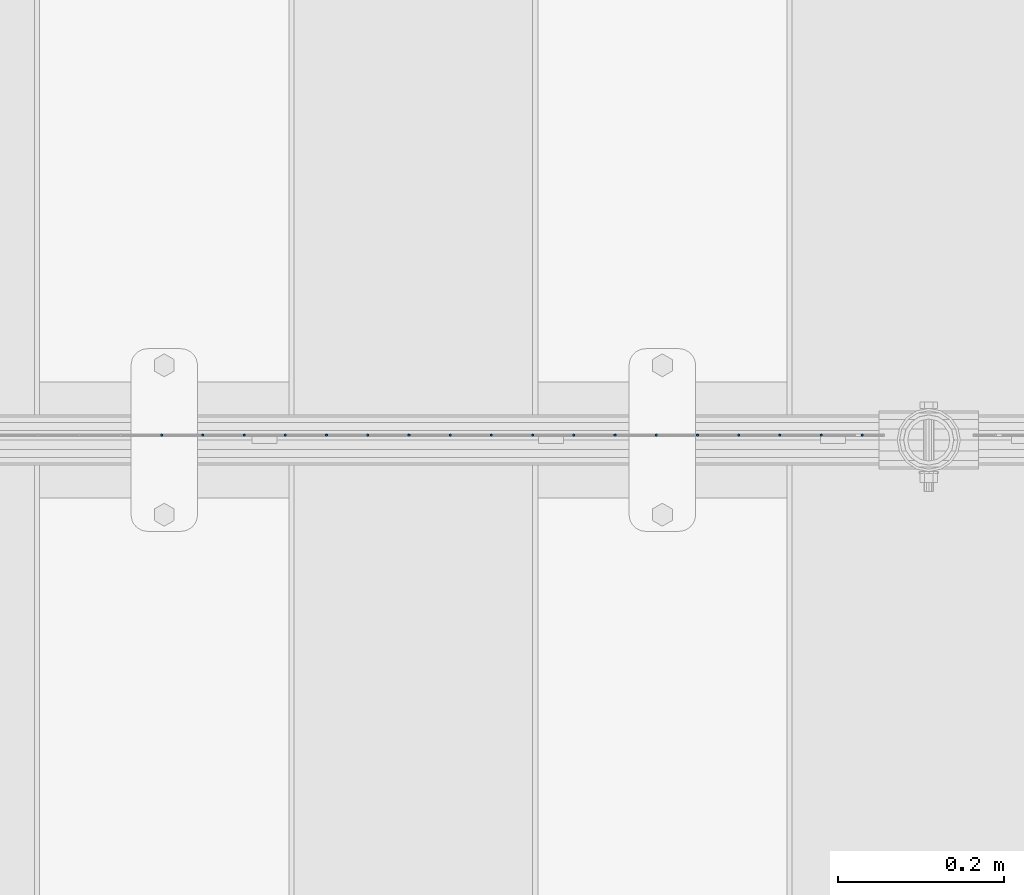
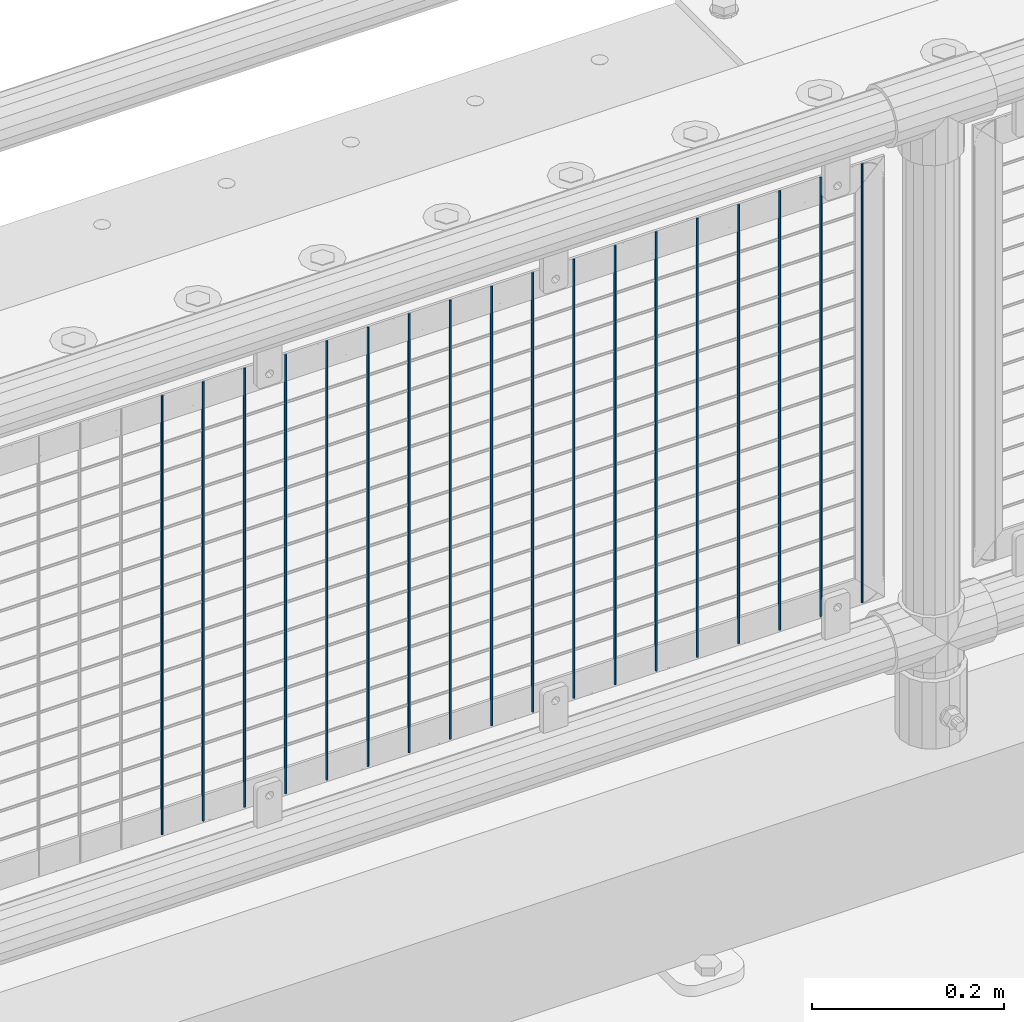
# One storey, part 80 of 247: 18 columns.
"""IFC2X3 building model written with IfcOpenShell, lengths in millimetres."""

from ifc_helpers import new_model, si_unit, frame, origin_with_axes, place, context, subcontext, project, spatial, faceted_brep, material, type_object, element, save


model = new_model("IFC2X3")

# Units and contexts
model_context = context("Model", 3, precision=1e-05, world=origin_with_axes())
body_context = subcontext(model_context, "Body", "Model", "MODEL_VIEW")
ifc_project = project(units=[si_unit("LENGTHUNIT", "METRE", prefix="MILLI"), si_unit("AREAUNIT", "SQUARE_METRE"), si_unit("VOLUMEUNIT", "CUBIC_METRE"), si_unit("MASSUNIT", "GRAM", prefix="KILO"), si_unit("TIMEUNIT", "SECOND"), si_unit("PLANEANGLEUNIT", "RADIAN"), si_unit("SOLIDANGLEUNIT", "STERADIAN"), si_unit("THERMODYNAMICTEMPERATUREUNIT", "DEGREE_CELSIUS"), si_unit("LUMINOUSINTENSITYUNIT", "LUMEN")], contexts=[model_context])

# Site, building, storey
site_placement = place(None, origin_with_axes())
site = spatial("IfcSite", under=ifc_project, at=site_placement, CompositionType="ELEMENT")
building_placement = place(site_placement, origin_with_axes())
building = spatial("IfcBuilding", under=site, at=building_placement, Name="Standard", CompositionType="ELEMENT")
storey_placement = place(building_placement, origin_with_axes())
storey = spatial("IfcBuildingStorey", under=building, at=storey_placement, Name="Undefined", CompositionType="ELEMENT", Elevation=0.0)

# Columns
ifc_material = material(Name="Misc_Undefined")
column_type = type_object("IfcColumnType", Name="D3", PredefinedType="NOTDEFINED")
for number, where, z_axis, x_axis in (
    (1, (6940.995, 7670.50000000001, 353.020000000001), (-1.0, 0.0, 0.0), (0.0, 0.0, 1.0)),
    (2, (6891.34, 7670.50000000001, 353.020000000001), (-1.0, 0.0, 0.0), (0.0, 0.0, 1.0)),
    (3, (6841.685, 7670.50000000001, 353.020000000001), (-1.0, 0.0, 0.0), (0.0, 0.0, 1.0)),
    (4, (6792.03, 7670.50000000001, 353.020000000001), (-1.0, 0.0, 0.0), (0.0, 0.0, 1.0)),
    (5, (6742.375, 7670.5, 353.020000000001), (-1.0, 0.0, 0.0), (0.0, 0.0, 1.0)),
    (6, (6692.72, 7670.5, 353.020000000001), (-1.0, 0.0, 0.0), (0.0, 0.0, 1.0)),
    (7, (6643.065, 7670.5, 353.020000000001), (-1.0, 0.0, 0.0), (0.0, 0.0, 1.0)),
    (8, (6593.41, 7670.5, 353.020000000001), (-1.0, 0.0, 0.0), (0.0, 0.0, 1.0)),
    (9, (6543.755, 7670.5, 353.020000000001), (-1.0, 0.0, 0.0), (0.0, 0.0, 1.0)),
    (10, (6494.1, 7670.5, 353.020000000001), (-1.0, 0.0, 0.0), (0.0, 0.0, 1.0)),
    (11, (6444.445, 7670.5, 353.020000000001), (-1.0, 0.0, 0.0), (0.0, 0.0, 1.0)),
    (12, (6394.79, 7670.5, 353.020000000001), (-1.0, 0.0, 0.0), (0.0, 0.0, 1.0)),
    (13, (6345.135, 7670.5, 353.020000000001), (-1.0, 0.0, 0.0), (0.0, 0.0, 1.0)),
    (14, (6295.48, 7670.5, 353.020000000001), (-1.0, 0.0, 0.0), (0.0, 0.0, 1.0)),
    (15, (6245.825, 7670.5, 353.020000000001), (-1.0, 0.0, 0.0), (0.0, 0.0, 1.0)),
    (16, (6196.17, 7670.5, 353.020000000001), (-1.0, 0.0, 0.0), (0.0, 0.0, 1.0)),
    (17, (6146.515, 7670.5, 353.020000000001), (-1.0, 0.0, 0.0), (0.0, 0.0, 1.0)),
    (18, (6096.86, 7670.5, 353.020000000001), (-1.0, 0.0, 0.0), (0.0, 0.0, 1.0)),
):
    element("IfcColumn", number, at=place(storey_placement, frame(where, z_axis=z_axis, x_axis=x_axis)), inside=storey, type_object=column_type, material=ifc_material, ObjectType="D3", context=body_context, shape_type="Brep", body=[
        faceted_brep([(1.81898940354586e-12, -1.5, -5.6843418860808e-14), (0.0, -0.75, -1.29903810567703), (560.0, -0.75, -1.29903810567703), (560.0, -1.5, 0.0), (0.0, 0.75, -1.29903810567703), (560.0, 0.75, -1.29903810567703), (1.81898940354586e-12, 1.5, -5.6843418860808e-14), (560.0, 1.5, 0.0), (0.0, 0.75, 1.29903810567703), (560.0, 0.75, 1.29903810567703), (0.0, -0.75, 1.29903810567703), (560.0, -0.75, 1.29903810567703)], [[[0, 1, 2, 3]], [[1, 4, 5, 2]], [[4, 6, 7, 5]], [[6, 8, 9, 7]], [[8, 10, 11, 9]], [[10, 0, 3, 11]], [[5, 7, 9, 11, 3, 2]], [[10, 8, 6, 4, 1, 0]]]),
    ])

save(model, "model.ifc")
